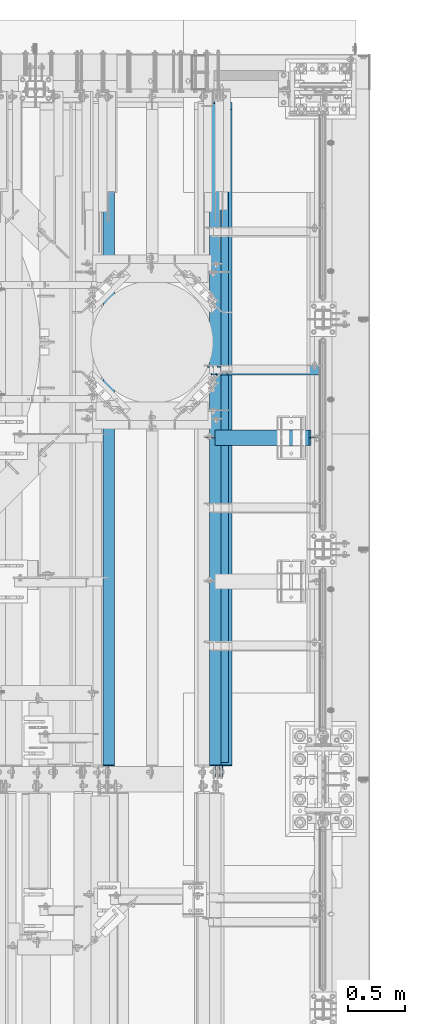
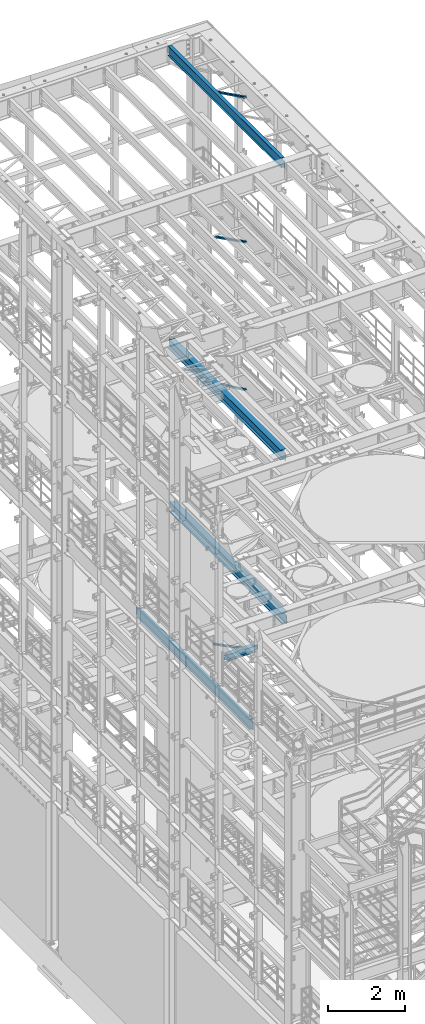
# One storey, part 1063 of 1876: 5 beams, 4 members, 9 elements without a shape of their own.
"""IFC2X3 building model written with IfcOpenShell, lengths in millimetres."""

from ifc_helpers import new_model, si_unit, frame, origin_with_axes, place, context, subcontext, project, spatial, faceted_brep, material, type_object, element, aggregate, save


model = new_model("IFC2X3")

# Units and contexts
model_context = context("Model", 3, precision=1e-05, world=origin_with_axes())
body_context = subcontext(model_context, "Body", "Model", "MODEL_VIEW")
ifc_project = project(units=[si_unit("LENGTHUNIT", "METRE", prefix="MILLI"), si_unit("AREAUNIT", "SQUARE_METRE"), si_unit("VOLUMEUNIT", "CUBIC_METRE"), si_unit("MASSUNIT", "GRAM", prefix="KILO"), si_unit("TIMEUNIT", "SECOND"), si_unit("PLANEANGLEUNIT", "RADIAN"), si_unit("SOLIDANGLEUNIT", "STERADIAN"), si_unit("THERMODYNAMICTEMPERATUREUNIT", "DEGREE_CELSIUS"), si_unit("LUMINOUSINTENSITYUNIT", "LUMEN")], contexts=[model_context])

# Site, building, storey
site_placement = place(None, origin_with_axes())
site = spatial("IfcSite", under=ifc_project, at=site_placement, CompositionType="ELEMENT")
building_placement = place(site_placement, origin_with_axes())
building = spatial("IfcBuilding", under=site, at=building_placement, Name="Undefined", CompositionType="ELEMENT")
storey_placement = place(building_placement, origin_with_axes())
storey = spatial("IfcBuildingStorey", under=building, at=storey_placement, Name="Undefined", CompositionType="ELEMENT", Elevation=0.0)

# Assembly, member
assembly_1_placement = place(storey_placement, origin_with_axes())
assembly_1 = element("IfcElementAssembly", 1, at=assembly_1_placement, inside=storey, AssemblyPlace="NOTDEFINED", PredefinedType="RIGID_FRAME")
ifc_material_1 = material(Name="STEEL/A36")
member_type = type_object("IfcMemberType", Name="L3X3X3/8", PredefinedType="NOTDEFINED")
member_1_placement = place(assembly_1_placement, frame((6546.00359127146, 11229.975, 5110.24886127725), z_axis=(0.0, -1.0, 0.0), x_axis=(0.894904191539842, 0.0, -0.446258319770535)))
member_1 = element("IfcMember", 2, at=member_1_placement, type_object=member_type, material=ifc_material_1, ObjectType="L3X3X3/8", context=body_context, shape_type="Brep", body=[
    faceted_brep([(80.1547206858395, 38.100000000054, -38.1000000000004), (80.1547206858395, 38.100000000054, 38.1000000000004), (1158.95112186373, 38.1000000006807, 38.1000000000004), (1158.95112186373, 38.1000000006807, -38.1000000000004), (80.1547206858399, 28.5750000000526, 38.1000000000004), (1158.95112186373, 28.5750000006792, 38.1000000000004), (80.1547206858399, 28.5750000000526, -28.5750000000007), (1158.95112186373, 28.5750000006792, -28.5750000000007), (80.154720685839, -38.0999999999594, -28.5750000000007), (1158.95112186373, -38.0999999993337, -28.5750000000007), (80.154720685839, -38.0999999999594, -38.1000000000004), (1158.95112186373, -38.0999999993337, -38.1000000000004)], [[[0, 1, 2, 3]], [[1, 4, 5, 2]], [[4, 6, 7, 5]], [[6, 8, 9, 7]], [[8, 10, 11, 9]], [[10, 0, 3, 11]], [[5, 7, 9, 11, 3, 2]], [[10, 8, 6, 4, 1, 0]]]),
])
aggregate(assembly_1, [member_1])

assembly_2_placement = place(storey_placement, origin_with_axes())
assembly_2 = element("IfcElementAssembly", 3, at=assembly_2_placement, inside=storey, Name="BRACE", AssemblyPlace="NOTDEFINED", PredefinedType="RIGID_FRAME")
member_2_placement = place(assembly_2_placement, frame((6673.56288393271, 11229.975, 13302.1718727092), z_axis=(0.0, -1.0, 0.0), x_axis=(0.861630637805759, 0.0, -0.507535854885584)))
member_2 = element("IfcMember", 4, at=member_2_placement, type_object=member_type, material=ifc_material_1, Name="BRACE", ObjectType="L3X3X3/8", context=body_context, shape_type="Brep", body=[
    faceted_brep([(93.8357350541173, 38.0999999999913, -38.0999999999999), (93.8357350541173, 38.0999999999913, 38.0999999999999), (1052.95263444459, 38.0999999997257, 38.0999999999999), (1052.95263444459, 38.0999999997257, -38.0999999999999), (93.8357350541228, 28.5749999999862, 38.0999999999999), (1052.95263444459, 28.5749999997206, 38.0999999999999), (93.8357350541228, 28.5749999999862, -28.5749999999998), (1052.95263444459, 28.5749999997206, -28.5749999999998), (93.8357350541537, -38.100000000044, -28.5749999999998), (1052.95263444462, -38.100000000306, -28.5749999999998), (93.8357350541537, -38.100000000044, -38.0999999999999), (1052.95263444462, -38.100000000306, -38.0999999999999)], [[[0, 1, 2, 3]], [[1, 4, 5, 2]], [[4, 6, 7, 5]], [[6, 8, 9, 7]], [[8, 10, 11, 9]], [[10, 0, 3, 11]], [[5, 7, 9, 11, 3, 2]], [[10, 8, 6, 4, 1, 0]]]),
])
aggregate(assembly_2, [member_2])

assembly_3_placement = place(storey_placement, origin_with_axes())
assembly_3 = element("IfcElementAssembly", 5, at=assembly_3_placement, inside=storey, AssemblyPlace="NOTDEFINED", PredefinedType="RIGID_FRAME")
member_3_placement = place(assembly_3_placement, frame((6649.22451200342, 11229.975, 22521.7692276093), z_axis=(0.0, -1.0, 0.0), x_axis=(0.877448093107094, 0.0, -0.479671600058544)))
member_3 = element("IfcMember", 6, at=member_3_placement, type_object=member_type, material=ifc_material_1, ObjectType="L3X3X3/8", context=body_context, shape_type="Brep", body=[
    faceted_brep([(59.7482362440578, 38.0999999998749, -38.0999999999999), (59.7482362440578, 38.0999999998749, 38.0999999999999), (1062.91900040893, 38.0999999984488, 38.0999999999999), (1062.91900040893, 38.0999999984488, -38.0999999999999), (59.7482362440696, 28.5749999998843, 38.0999999999999), (1062.91900040895, 28.5749999984582, 38.0999999999999), (59.7482362440696, 28.5749999998843, -28.5749999999998), (1062.91900040895, 28.5749999984582, -28.5749999999998), (59.7482362441442, -38.1000000000495, -28.5749999999998), (1062.91900040902, -38.1000000014719, -28.5749999999998), (59.7482362441442, -38.1000000000495, -38.0999999999999), (1062.91900040902, -38.1000000014719, -38.0999999999999)], [[[0, 1, 2, 3]], [[1, 4, 5, 2]], [[4, 6, 7, 5]], [[6, 8, 9, 7]], [[8, 10, 11, 9]], [[10, 0, 3, 11]], [[5, 7, 9, 11, 3, 2]], [[10, 8, 6, 4, 1, 0]]]),
])
aggregate(assembly_3, [member_3])

assembly_4_placement = place(storey_placement, origin_with_axes())
assembly_4 = element("IfcElementAssembly", 7, at=assembly_4_placement, inside=storey, AssemblyPlace="NOTDEFINED", PredefinedType="RIGID_FRAME")
member_4_placement = place(assembly_4_placement, frame((6548.05484608427, 11229.975, 17987.6375508032), z_axis=(0.0, -1.0, 0.0), x_axis=(0.883528850284789, 0.0, -0.46837674015096)))
member_4 = element("IfcMember", 8, at=member_4_placement, type_object=member_type, material=ifc_material_1, ObjectType="L3X3X3/8", context=body_context, shape_type="Brep", body=[
    faceted_brep([(128.795891913077, 38.1000000000095, -38.0999999999999), (128.795891913077, 38.1000000000095, 38.0999999999999), (1170.59703232476, 38.0999999999913, 38.0999999999999), (1170.59703232476, 38.0999999999913, -38.0999999999999), (128.795891913076, 28.575000000008, 38.0999999999999), (1170.59703232476, 28.5749999999898, 38.0999999999999), (128.795891913076, 28.575000000008, -28.5749999999998), (1170.59703232476, 28.5749999999898, -28.5749999999998), (128.79589191308, -38.1000000000167, -28.5749999999998), (1170.59703232476, -38.1000000000313, -28.5749999999998), (128.79589191308, -38.1000000000167, -38.0999999999999), (1170.59703232476, -38.1000000000313, -38.0999999999999)], [[[0, 1, 2, 3]], [[1, 4, 5, 2]], [[4, 6, 7, 5]], [[6, 8, 9, 7]], [[8, 10, 11, 9]], [[10, 0, 3, 11]], [[5, 7, 9, 11, 3, 2]], [[10, 8, 6, 4, 1, 0]]]),
])
aggregate(assembly_4, [member_4])

# Assembly, beam
assembly_5_placement = place(storey_placement, origin_with_axes())
assembly_5 = element("IfcElementAssembly", 9, at=assembly_5_placement, inside=storey, Name="BEAM", AssemblyPlace="NOTDEFINED", PredefinedType="RIGID_FRAME")
ifc_material_2 = material(Name="STEEL/A992")
beam_type_1 = type_object("IfcBeamType", Name="W12X16", PredefinedType="NOTDEFINED")
beam_1_placement = place(assembly_5_placement, frame((6667.5, 7620.0, 22402.8), z_axis=(0.0, 0.0, 1.0), x_axis=(0.0, 1.0, 0.0)))
beam_1 = element("IfcBeam", 10, at=beam_1_placement, type_object=beam_type_1, material=ifc_material_2, Name="BEAM", ObjectType="W12X16", context=body_context, shape_type="Brep", body=[
    faceted_brep([(19.84375, -3.17499999999995, -126.999999999996), (19.84375, 3.17499999999995, -126.999999999996), (102.393750190735, 3.17500000000018, -127.000000000001), (102.393750190735, -3.17500000000018, -127.000000000001), (107.25382970878, 3.17500000000018, -127.966729922588), (107.25382970878, -3.17500000000018, -127.966729922588), (111.374006176934, 3.17500000000018, -130.719743823067), (111.374006176934, -3.17500000000018, -130.719743823067), (114.127020077412, 3.17500000000018, -134.839920291221), (114.127020077412, -3.17500000000018, -134.839920291221), (115.09375, -3.17500000000018, -139.699999809266), (115.09375, 3.17500000000018, -139.699999809266), (115.09375, 3.17500000000018, -146.05), (115.09375, 50.8000000000002, -146.05), (115.09375, 50.8000000000002, -152.4), (115.09375, -50.8000000000002, -152.4), (115.09375, -50.8000000000002, -146.05), (115.09375, -3.17500000000018, -146.05), (127.79375, 3.17500000000018, 146.05), (127.79375, 50.8000000000002, 146.05), (5968.20625, 50.8, 146.05), (5968.20625, 3.17499999999995, 146.05), (115.093750190735, -3.17500000000018, 114.299999999999), (115.093750190735, 3.17500000000018, 114.299999999999), (19.84375, 3.17500000000018, 114.299999999999), (19.84375, -3.17500000000018, 114.299999999999), (119.95382970878, -3.17500000000018, 115.266729922587), (119.95382970878, 3.17500000000018, 115.266729922587), (124.074006176934, -3.17500000000018, 118.019743823065), (124.074006176934, 3.17500000000018, 118.019743823065), (126.827020077412, -3.17500000000018, 122.139920291219), (126.827020077412, 3.17500000000018, 122.139920291219), (127.79375, -3.17500000000018, 126.999999809264), (127.79375, 3.17500000000018, 126.999999809264), (127.79375, 50.8000000000002, 152.4), (127.79375, -50.8000000000002, 152.4), (5968.20625, -50.8, 152.4), (5968.20625, 50.8, 152.4), (127.79375, -50.8000000000002, 146.05), (5968.20625, -50.8, 146.05), (127.79375, -3.17500000000018, 146.05), (5968.20625, -3.17499999999995, 146.05), (5968.20625, -3.17499999999995, 126.999999809264), (5968.20625, 3.17499999999995, 126.999999809264), (5969.17297992259, -3.17499999999995, 122.139920291219), (5969.17297992259, 3.17499999999995, 122.139920291219), (5971.92599382307, -3.17499999999995, 118.019743823065), (5971.92599382307, 3.17499999999995, 118.019743823065), (5976.04617029122, -3.17499999999995, 115.266729922587), (5976.04617029122, 3.17499999999995, 115.266729922587), (5980.90624980927, -3.17499999999995, 114.299999999999), (5980.90624980927, 3.17499999999995, 114.299999999999), (6076.15625, -3.17499999999995, 114.299999999999), (6076.15625, 3.17499999999995, 114.299999999999), (6076.15625, -3.17499999999995, -126.999999999996), (6076.15625, 3.17499999999995, -126.999999999996), (5993.60624980927, -3.17499999999995, -127.000000000001), (5993.60624980927, 3.17499999999995, -127.000000000001), (5988.74617029122, -3.17499999999995, -127.966729922588), (5988.74617029122, 3.17499999999995, -127.966729922588), (5984.62599382307, -3.17499999999995, -130.719743823067), (5984.62599382307, 3.17499999999995, -130.719743823067), (5981.87297992259, -3.17499999999995, -134.839920291221), (5981.87297992259, 3.17499999999995, -134.839920291221), (5980.90625, -3.17499999999995, -139.699999809266), (5980.90625, 3.17499999999995, -139.699999809266), (5980.90625, -3.17499999999995, -146.05), (5980.90625, -50.8, -146.05), (5980.90625, -50.8, -152.4), (5980.90625, 50.8, -152.4), (5980.90625, 50.8, -146.05), (5980.90625, 3.17499999999995, -146.05)], [[[0, 1, 2, 3]], [[3, 2, 4, 5]], [[5, 4, 6, 7]], [[7, 6, 8, 9]], [[10, 11, 12, 13, 14, 15, 16, 17]], [[9, 8, 11, 10]], [[18, 19, 20, 21]], [[22, 23, 24, 25]], [[26, 27, 23, 22]], [[28, 29, 27, 26]], [[30, 31, 29, 28]], [[32, 33, 31, 30]], [[34, 35, 36, 37]], [[35, 38, 39, 36]], [[38, 40, 41, 39]], [[35, 34, 19, 18, 33, 32, 40, 38]], [[19, 34, 37, 20]], [[36, 39, 41, 42, 43, 21, 20, 37]], [[44, 45, 43, 42]], [[46, 47, 45, 44]], [[48, 49, 47, 46]], [[50, 51, 49, 48]], [[52, 53, 51, 50]], [[53, 52, 54, 55]], [[54, 56, 57, 55]], [[58, 59, 57, 56]], [[60, 61, 59, 58]], [[62, 63, 61, 60]], [[64, 65, 63, 62]], [[66, 67, 68, 69, 70, 71, 65, 64]], [[17, 16, 67, 66]], [[16, 15, 68, 67]], [[15, 14, 69, 68]], [[14, 13, 70, 69]], [[13, 12, 71, 70]], [[59, 61, 63, 65, 71, 12, 11, 8, 6, 4, 2, 1, 24, 23, 27, 29, 31, 33, 18, 21, 43, 45, 47, 49, 51, 53, 55, 57]], [[25, 24, 1, 0]], [[52, 50, 48, 46, 44, 42, 41, 40, 32, 30, 28, 26, 22, 25, 0, 3, 5, 7, 9, 10, 17, 66, 64, 62, 60, 58, 56, 54]]]),
])
aggregate(assembly_5, [beam_1])

assembly_6_placement = place(storey_placement, origin_with_axes())
assembly_6 = element("IfcElementAssembly", 11, at=assembly_6_placement, inside=storey, Name="BEAM", AssemblyPlace="NOTDEFINED", PredefinedType="RIGID_FRAME")
beam_2_placement = place(assembly_6_placement, frame((5727.7, 7620.0, 4978.4), z_axis=(0.0, 0.0, 1.0), x_axis=(0.0, 1.0, 0.0)))
beam_2 = element("IfcBeam", 12, at=beam_2_placement, type_object=beam_type_1, material=ifc_material_2, Name="BEAM", ObjectType="W12X16", context=body_context, shape_type="Brep", body=[
    faceted_brep([(19.84375, -3.17499999999995, -126.999999999996), (19.84375, 3.17499999999995, -126.999999999996), (102.393750190735, 3.17500000000018, -127.000000000001), (102.393750190735, -3.17500000000018, -127.000000000001), (107.25382970878, 3.17500000000018, -127.966729922588), (107.25382970878, -3.17500000000018, -127.966729922588), (111.374006176934, 3.17500000000018, -130.719743823067), (111.374006176934, -3.17500000000018, -130.719743823067), (114.127020077412, 3.17500000000018, -134.839920291221), (114.127020077412, -3.17500000000018, -134.839920291221), (115.09375, -3.17500000000018, -139.699999809266), (115.09375, 3.17500000000018, -139.699999809266), (115.09375, 3.17500000000018, -146.05), (115.09375, 50.8000000000002, -146.05), (115.09375, 50.8000000000002, -152.4), (115.09375, -50.8000000000002, -152.4), (115.09375, -50.8000000000002, -146.05), (115.09375, -3.17500000000018, -146.05), (5914.23125, 50.8, 146.05), (5914.23125, 3.17500000000018, 146.05), (127.79375, 3.17500000000018, 146.05), (127.79375, 50.8000000000002, 146.05), (115.093750190735, -3.17500000000018, 114.299999999999), (115.093750190735, 3.17500000000018, 114.299999999999), (19.84375, 3.17500000000018, 114.299999999999), (19.84375, -3.17500000000018, 114.299999999999), (119.95382970878, -3.17500000000018, 115.266729922587), (119.95382970878, 3.17500000000018, 115.266729922587), (124.074006176934, -3.17500000000018, 118.019743823065), (124.074006176934, 3.17500000000018, 118.019743823065), (126.827020077412, -3.17500000000018, 122.139920291219), (126.827020077412, 3.17500000000018, 122.139920291219), (127.79375, -3.17500000000018, 126.999999809264), (127.79375, 3.17500000000018, 126.999999809264), (5914.23125, -50.8, 152.4), (5914.23125, 50.8, 152.4), (127.79375, 50.8000000000002, 152.4), (127.79375, -50.8000000000002, 152.4), (5914.23125, -50.8, 146.05), (127.79375, -50.8000000000002, 146.05), (5914.23125, -3.17500000000018, 146.05), (127.79375, -3.17500000000018, 146.05), (5914.23125, -3.17499999999995, 114.299999809266), (5914.23125, 3.17499999999995, 114.299999809266), (5915.19797992259, -3.17499999999995, 109.43992029122), (5915.19797992259, 3.17499999999995, 109.43992029122), (5917.95099382307, -3.17499999999995, 105.319743823066), (5917.95099382307, 3.17499999999995, 105.319743823066), (5922.07117029122, -3.17499999999995, 102.566729922588), (5922.07117029122, 3.17499999999995, 102.566729922588), (5926.93124980926, -3.17499999999995, 101.6), (5926.93124980926, 3.17499999999995, 101.6), (6072.98125, -3.17499999999995, 101.6), (6072.98125, 3.17499999999995, 101.6), (6072.98125, -3.17499999999995, -127.0), (6072.98125, 3.17499999999995, -127.0), (5990.43124980926, -3.17499999999995, -127.0), (5990.43124980926, 3.17499999999995, -127.0), (5985.57117029122, -3.17499999999995, -127.966729922588), (5985.57117029122, 3.17499999999995, -127.966729922588), (5981.45099382307, -3.17499999999995, -130.719743823066), (5981.45099382307, 3.17499999999995, -130.719743823066), (5978.69797992259, -3.17499999999995, -134.83992029122), (5978.69797992259, 3.17499999999995, -134.83992029122), (5977.73125, -3.17499999999995, -139.699999809265), (5977.73125, 3.17499999999995, -139.699999809265), (5977.73125, -3.17500000000018, -146.05), (5977.73125, -50.8, -146.05), (5977.73125, -50.8, -152.4), (5977.73125, 50.8, -152.4), (5977.73125, 50.8, -146.05), (5977.73125, 3.17500000000018, -146.05)], [[[0, 1, 2, 3]], [[3, 2, 4, 5]], [[5, 4, 6, 7]], [[7, 6, 8, 9]], [[10, 11, 12, 13, 14, 15, 16, 17]], [[9, 8, 11, 10]], [[18, 19, 20, 21]], [[22, 23, 24, 25]], [[26, 27, 23, 22]], [[28, 29, 27, 26]], [[30, 31, 29, 28]], [[32, 33, 31, 30]], [[34, 35, 36, 37]], [[38, 34, 37, 39]], [[40, 38, 39, 41]], [[37, 36, 21, 20, 33, 32, 41, 39]], [[35, 18, 21, 36]], [[34, 38, 40, 42, 43, 19, 18, 35]], [[44, 45, 43, 42]], [[46, 47, 45, 44]], [[48, 49, 47, 46]], [[50, 51, 49, 48]], [[52, 53, 51, 50]], [[53, 52, 54, 55]], [[54, 56, 57, 55]], [[58, 59, 57, 56]], [[60, 61, 59, 58]], [[62, 63, 61, 60]], [[64, 65, 63, 62]], [[66, 67, 68, 69, 70, 71, 65, 64]], [[67, 66, 17, 16]], [[68, 67, 16, 15]], [[69, 68, 15, 14]], [[70, 69, 14, 13]], [[71, 70, 13, 12]], [[6, 4, 2, 1, 24, 23, 27, 29, 31, 33, 20, 19, 43, 45, 47, 49, 51, 53, 55, 57, 59, 61, 63, 65, 71, 12, 11, 8]], [[25, 24, 1, 0]], [[66, 64, 62, 60, 58, 56, 54, 52, 50, 48, 46, 44, 42, 40, 41, 32, 30, 28, 26, 22, 25, 0, 3, 5, 7, 9, 10, 17]]]),
])
aggregate(assembly_6, [beam_2])

assembly_7_placement = place(storey_placement, origin_with_axes())
assembly_7 = element("IfcElementAssembly", 13, at=assembly_7_placement, inside=storey, Name="BEAM", AssemblyPlace="NOTDEFINED", PredefinedType="RIGID_FRAME")
beam_type_2 = type_object("IfcBeamType", Name="W8X18", PredefinedType="NOTDEFINED")
beam_3_placement = place(assembly_7_placement, frame((6553.2, 10636.25, 5027.6125), z_axis=(0.0, 0.0, 1.0), x_axis=(1.0, 0.0, 0.0)))
beam_3 = element("IfcBeam", 14, at=beam_3_placement, type_object=beam_type_2, material=ifc_material_2, Name="BEAM", ObjectType="W8X18", context=body_context, shape_type="Brep", body=[
    faceted_brep([(958.056250000001, -3.17499999999927, -95.25), (958.056250000001, -66.6749999999993, -95.25), (958.056250000002, -66.6749999999993, -103.1875), (958.056250000002, 66.6749999999993, -103.1875), (958.056250000001, 66.6749999999993, -95.25), (958.056250000001, 3.17499999999927, -95.25), (958.056250000001, 3.17499999999927, -90.4874998092664), (958.056250000001, -3.17499999999927, -90.4874998092664), (959.022979922589, 3.17499999999927, -85.6274202912209), (959.022979922589, -3.17499999999927, -85.6274202912209), (961.775993823067, 3.17499999999927, -81.5072438230673), (961.775993823067, -3.17499999999927, -81.5072438230673), (965.896170291221, 3.17499999999927, -78.7542299225888), (965.896170291221, -3.17499999999927, -78.7542299225888), (970.756249809267, 3.17499999999927, -77.7875000000013), (970.756249809267, -3.17499999999927, -77.7875000000013), (1046.95625, -3.17499999999927, -77.7875000000013), (1046.95625, 3.17499999999927, -77.7875000000013), (111.125000000002, 3.17499999999927, 95.25), (111.125000000002, 66.6749999999993, 95.25), (940.593750000002, 66.6749999999993, 95.25), (940.593750000002, 3.17499999999927, 95.25), (117.475000000001, -3.17499999999927, -90.4874998092664), (117.475000000001, 3.17499999999927, -90.4874998092664), (117.475000000001, 3.17499999999927, -95.25), (117.475000000001, 66.6749999999993, -95.25), (117.475000000001, 66.6749999999993, -103.1875), (117.475000000001, -66.6749999999993, -103.1875), (117.475000000001, -66.6749999999993, -95.25), (117.475000000001, -3.17499999999927, -95.25), (116.508270077414, -3.17499999999927, -85.6274202912209), (116.508270077414, 3.17499999999927, -85.6274202912209), (113.755256176935, -3.17499999999927, -81.5072438230673), (113.755256176935, 3.17499999999927, -81.5072438230673), (109.635079708782, -3.17499999999927, -78.7542299225888), (109.635079708782, 3.17499999999927, -78.7542299225888), (104.775000190736, -3.17499999999927, -77.7875000000013), (104.775000190736, 3.17499999999927, -77.7875000000013), (28.5750000000016, -3.17499999999927, -77.7875000000013), (28.5750000000016, 3.17499999999927, -77.7875000000013), (28.5750000000016, -3.17499999999927, 77.7875000000013), (28.5750000000016, 3.17499999999927, 77.7875000000013), (98.4250001907367, -3.17499999999927, 77.7875000000013), (98.4250001907367, 3.17499999999927, 77.7875000000013), (103.285079708782, -3.17499999999927, 78.7542299225888), (103.285079708782, 3.17499999999927, 78.7542299225888), (107.405256176936, -3.17499999999927, 81.5072438230673), (107.405256176936, 3.17499999999927, 81.5072438230673), (110.158270077414, -3.17499999999927, 85.6274202912209), (110.158270077414, 3.17499999999927, 85.6274202912209), (111.125000000002, -3.17499999999927, 90.4874998092664), (111.125000000002, 3.17499999999927, 90.4874998092664), (111.125000000002, -66.6749999999993, 103.1875), (111.125000000002, 66.6749999999993, 103.1875), (111.125000000002, -3.17499999999927, 95.25), (111.125000000002, -66.6749999999993, 95.25), (940.593750000002, -3.17499999999927, 95.25), (940.593750000002, -66.6749999999993, 95.25), (940.593750000002, -66.6749999999993, 103.1875), (940.593750000002, 66.6749999999993, 103.1875), (940.593750000002, -3.17499999999927, 77.7874998092639), (940.593750000002, 3.17499999999927, 77.7874998092639), (941.560479922589, -3.17499999999927, 72.9274202912184), (941.560479922589, 3.17499999999927, 72.9274202912184), (944.313493823068, -3.17499999999927, 68.8072438230647), (944.313493823068, 3.17499999999927, 68.8072438230647), (948.433670291221, -3.17499999999927, 66.0542299225863), (948.433670291221, 3.17499999999927, 66.0542299225863), (953.293749809267, -3.17499999999927, 65.0874999999987), (953.293749809267, 3.17499999999927, 65.0874999999987), (1046.95625, -3.17499999999927, 65.0874999999987), (1046.95625, 3.17499999999927, 65.0874999999987)], [[[0, 1, 2, 3, 4, 5, 6, 7]], [[7, 6, 8, 9]], [[9, 8, 10, 11]], [[11, 10, 12, 13]], [[13, 12, 14, 15]], [[16, 15, 14, 17]], [[18, 19, 20, 21]], [[22, 23, 24, 25, 26, 27, 28, 29]], [[30, 31, 23, 22]], [[32, 33, 31, 30]], [[34, 35, 33, 32]], [[36, 37, 35, 34]], [[38, 39, 37, 36]], [[40, 41, 39, 38]], [[42, 43, 41, 40]], [[44, 45, 43, 42]], [[46, 47, 45, 44]], [[48, 49, 47, 46]], [[50, 51, 49, 48]], [[52, 53, 19, 18, 51, 50, 54, 55]], [[55, 54, 56, 57]], [[52, 55, 57, 58]], [[53, 52, 58, 59]], [[19, 53, 59, 20]], [[58, 57, 56, 60, 61, 21, 20, 59]], [[62, 63, 61, 60]], [[64, 65, 63, 62]], [[66, 67, 65, 64]], [[68, 69, 67, 66]], [[70, 71, 69, 68]], [[71, 70, 16, 17]], [[12, 10, 8, 6, 5, 24, 23, 31, 33, 35, 37, 39, 41, 43, 45, 47, 49, 51, 18, 21, 61, 63, 65, 67, 69, 71, 17, 14]], [[25, 24, 5, 4]], [[26, 25, 4, 3]], [[27, 26, 3, 2]], [[28, 27, 2, 1]], [[29, 28, 1, 0]], [[70, 68, 66, 64, 62, 60, 56, 54, 50, 48, 46, 44, 42, 40, 38, 36, 34, 32, 30, 22, 29, 0, 7, 9, 11, 13, 15, 16]]]),
])
aggregate(assembly_7, [beam_3])

assembly_8_placement = place(storey_placement, origin_with_axes())
assembly_8 = element("IfcElementAssembly", 15, at=assembly_8_placement, inside=storey, Name="BEAM", AssemblyPlace="NOTDEFINED", PredefinedType="RIGID_FRAME")
beam_type_3 = type_object("IfcBeamType", Name="W12X30", PredefinedType="NOTDEFINED")
beam_4_placement = place(assembly_8_placement, frame((6702.425, 7620.0, 13152.4375), z_axis=(0.0, 0.0, 1.0), x_axis=(0.0, 1.0, 0.0)))
beam_4 = element("IfcBeam", 16, at=beam_4_placement, type_object=beam_type_3, material=ifc_material_2, Name="BEAM", ObjectType="W12X30", context=body_context, shape_type="Brep", body=[
    faceted_brep([(5973.7625, -3.17500000000018, -146.049999999999), (5973.7625, -82.5500000000002, -146.049999999999), (5973.7625, -82.5500000000002, -157.1625), (5973.7625, 82.5500000000002, -157.1625), (5973.7625, 82.5500000000002, -146.049999999999), (5973.7625, 3.17500000000018, -146.049999999999), (5973.7625, 3.17500000000018, -144.462499809264), (5973.7625, -3.17500000000018, -144.462499809264), (5974.72922992259, 3.17500000000018, -139.602420291218), (5974.72922992259, -3.17500000000018, -139.602420291218), (5977.48224382307, 3.17500000000018, -135.482243823064), (5977.48224382307, -3.17500000000018, -135.482243823064), (5981.60242029122, 3.17500000000018, -132.729229922586), (5981.60242029122, -3.17500000000018, -132.729229922586), (5986.46249980926, 3.17500000000018, -131.762499999999), (5986.46249980926, -3.17500000000018, -131.762499999999), (6075.3625, -3.17500000000018, -131.762499999999), (6075.3625, 3.17500000000018, -131.762499999999), (146.84375, 3.17500000000018, 146.049999999999), (146.84375, 82.5500000000002, 146.049999999999), (5910.2625, 82.5500000000002, 146.049999999999), (5910.2625, 3.17500000000018, 146.049999999999), (146.84375, -3.17500000000018, -144.462499809266), (146.84375, 3.17500000000018, -144.462499809266), (146.84375, 3.17500000000018, -146.049999999999), (146.84375, 82.5500000000002, -146.049999999999), (146.84375, 82.5500000000002, -157.1625), (146.84375, -82.5500000000002, -157.1625), (146.84375, -82.5500000000002, -146.049999999999), (146.84375, -3.17500000000018, -146.049999999999), (145.877020077412, -3.17500000000018, -139.602420291219), (145.877020077412, 3.17500000000018, -139.602420291219), (143.124006176934, -3.17500000000018, -135.482243823066), (143.124006176934, 3.17500000000018, -135.482243823066), (139.00382970878, -3.17500000000018, -132.729229922588), (139.00382970878, 3.17500000000018, -132.729229922588), (134.143750190735, -3.17500000000018, -131.762500000001), (134.143750190735, 3.17500000000018, -131.762500000001), (19.8437500000002, -3.17500000000018, -131.762499999993), (19.8437500000002, 3.17500000000018, -131.762499999993), (19.8437491105051, -3.17499999999995, 119.062500000004), (19.8437491105051, 3.17499999999995, 119.062500000004), (134.143750190735, -3.17500000000018, 119.0625), (134.143750190735, 3.17500000000018, 119.0625), (139.00382970878, -3.17500000000018, 120.029229922588), (139.00382970878, 3.17500000000018, 120.029229922588), (143.124006176934, -3.17500000000018, 122.782243823065), (143.124006176934, 3.17500000000018, 122.782243823065), (145.877020077412, -3.17500000000018, 126.902420291219), (145.877020077412, 3.17500000000018, 126.902420291219), (146.84375, -3.17500000000018, 131.762499809265), (146.84375, 3.17500000000018, 131.762499809265), (146.84375, -82.5500000000002, 157.1625), (146.84375, 82.5500000000002, 157.1625), (146.84375, -3.17500000000018, 146.049999999999), (146.84375, -82.5500000000002, 146.049999999999), (5910.2625, -3.17500000000018, 146.049999999999), (5910.2625, -82.5500000000002, 146.049999999999), (5910.2625, -82.5500000000002, 157.1625), (5910.2625, 82.5500000000002, 157.1625), (5910.2625, -3.17500000000018, 125.412499809268), (5910.2625, 3.17500000000018, 125.412499809268), (5911.22922992259, -3.17500000000018, 120.552420291222), (5911.22922992259, 3.17500000000018, 120.552420291222), (5913.98224382307, -3.17500000000018, 116.432243823068), (5913.98224382307, 3.17500000000018, 116.432243823068), (5918.10242029122, -3.17500000000018, 113.679229922591), (5918.10242029122, 3.17500000000018, 113.679229922591), (5922.96249980926, -3.17500000000018, 112.712500000003), (5922.96249980926, 3.17500000000018, 112.712500000003), (6075.3625, -3.17500000000018, 112.712500000003), (6075.3625, 3.17500000000018, 112.712500000003)], [[[0, 1, 2, 3, 4, 5, 6, 7]], [[7, 6, 8, 9]], [[9, 8, 10, 11]], [[11, 10, 12, 13]], [[13, 12, 14, 15]], [[16, 15, 14, 17]], [[18, 19, 20, 21]], [[22, 23, 24, 25, 26, 27, 28, 29]], [[30, 31, 23, 22]], [[32, 33, 31, 30]], [[34, 35, 33, 32]], [[36, 37, 35, 34]], [[38, 39, 37, 36]], [[40, 41, 39, 38]], [[42, 43, 41, 40]], [[44, 45, 43, 42]], [[46, 47, 45, 44]], [[48, 49, 47, 46]], [[50, 51, 49, 48]], [[52, 53, 19, 18, 51, 50, 54, 55]], [[55, 54, 56, 57]], [[52, 55, 57, 58]], [[53, 52, 58, 59]], [[19, 53, 59, 20]], [[58, 57, 56, 60, 61, 21, 20, 59]], [[62, 63, 61, 60]], [[64, 65, 63, 62]], [[66, 67, 65, 64]], [[68, 69, 67, 66]], [[70, 71, 69, 68]], [[71, 70, 16, 17]], [[12, 10, 8, 6, 5, 24, 23, 31, 33, 35, 37, 39, 41, 43, 45, 47, 49, 51, 18, 21, 61, 63, 65, 67, 69, 71, 17, 14]], [[25, 24, 5, 4]], [[26, 25, 4, 3]], [[27, 26, 3, 2]], [[28, 27, 2, 1]], [[29, 28, 1, 0]], [[70, 68, 66, 64, 62, 60, 56, 54, 50, 48, 46, 44, 42, 40, 38, 36, 34, 32, 30, 22, 29, 0, 7, 9, 11, 13, 15, 16]]]),
])
aggregate(assembly_8, [beam_4])

assembly_9_placement = place(storey_placement, origin_with_axes())
assembly_9 = element("IfcElementAssembly", 17, at=assembly_9_placement, inside=storey, Name="BEAM", AssemblyPlace="NOTDEFINED", PredefinedType="RIGID_FRAME")
beam_5_placement = place(assembly_9_placement, frame((6731.0, 7620.0, 7996.2375), z_axis=(0.0, 0.0, 1.0), x_axis=(0.0, 1.0, 0.0)))
beam_5 = element("IfcBeam", 18, at=beam_5_placement, type_object=beam_type_3, material=ifc_material_2, Name="BEAM", ObjectType="W12X30", context=body_context, shape_type="Brep", body=[
    faceted_brep([(19.8437500000002, -3.17500000000018, -131.762499999993), (19.8437500000002, 3.17500000000018, -131.762499999993), (102.393750190735, 3.17500000000018, -131.762500000001), (102.393750190735, -3.17500000000018, -131.762500000001), (107.25382970878, 3.17500000000018, -132.729229922588), (107.25382970878, -3.17500000000018, -132.729229922588), (111.374006176934, 3.17500000000018, -135.482243823067), (111.374006176934, -3.17500000000018, -135.482243823067), (114.127020077412, 3.17500000000018, -139.60242029122), (114.127020077412, -3.17500000000018, -139.60242029122), (115.09375, -3.17500000000018, -144.462499809266), (115.09375, 3.17500000000018, -144.462499809266), (115.09375, 3.17500000000018, -146.05), (115.09375, 82.5500000000002, -146.05), (115.09375, 82.5500000000002, -157.1625), (115.09375, -82.5500000000002, -157.1625), (115.09375, -82.5500000000002, -146.05), (115.09375, -3.17500000000018, -146.05), (5914.23125, 82.5500000000002, 146.05), (5914.23125, 3.17500000000018, 146.05), (127.79375, 3.17500000000018, 146.05), (127.793782276814, 82.5500000000102, 146.05), (115.09374930124, -3.17499999999995, 119.062500000004), (115.09374930124, 3.17499999999995, 119.062500000004), (19.8437491105051, 3.17499999999995, 119.062500000004), (19.8437491105051, -3.17499999999995, 119.062500000004), (119.953828819285, -3.17499999999995, 120.029229922591), (119.953828819285, 3.17499999999995, 120.029229922591), (124.074005287439, -3.17499999999995, 122.782243823069), (124.074005287439, 3.17499999999995, 122.782243823069), (126.827019187917, -3.17499999999995, 126.902420291222), (126.827019187917, 3.17499999999995, 126.902420291222), (127.793749110505, -3.17499999999995, 131.762499809269), (127.793749110505, 3.17499999999995, 131.762499809269), (5914.23125, -82.5500000000002, 157.1625), (5914.23125, 82.5500000000002, 157.1625), (127.793749110505, 82.55, 157.162499999999), (127.793749110505, -82.55, 157.162499999999), (5914.23125, -82.5500000000002, 146.05), (127.793782276821, -82.5500000000029, 146.05), (5914.23125, -3.17500000000018, 146.05), (127.79375, -3.17500000000018, 146.05), (5914.23125, -3.17500000000018, 119.062499809265), (5914.23125, 3.17500000000018, 119.062499809265), (5915.19797992259, -3.17500000000018, 114.20242029122), (5915.19797992259, 3.17500000000018, 114.20242029122), (5917.95099382307, -3.17500000000018, 110.082243823066), (5917.95099382307, 3.17500000000018, 110.082243823066), (5922.07117029122, -3.17500000000018, 107.329229922588), (5922.07117029122, 3.17500000000018, 107.329229922588), (5926.93124980926, -3.17500000000018, 106.3625), (5926.93124980926, 3.17500000000018, 106.3625), (6072.98125, -3.17500000000018, 106.3625), (6072.98125, 3.17500000000018, 106.3625), (6072.98125, -3.17500000000018, -131.7625), (6072.98125, 3.17500000000018, -131.7625), (5990.43124980926, -3.17500000000018, -131.7625), (5990.43124980926, 3.17500000000018, -131.7625), (5985.57117029122, -3.17500000000018, -132.729229922587), (5985.57117029122, 3.17500000000018, -132.729229922587), (5981.45099382307, -3.17500000000018, -135.482243823066), (5981.45099382307, 3.17500000000018, -135.482243823066), (5978.69797992259, -3.17500000000018, -139.602420291219), (5978.69797992259, 3.17500000000018, -139.602420291219), (5977.73125, -3.17500000000018, -144.462499809265), (5977.73125, 3.17500000000018, -144.462499809265), (5977.73125, -3.17500000000018, -146.05), (5977.73125, -82.5500000000002, -146.05), (5977.73125, -82.5500000000002, -157.1625), (5977.73125, 82.5500000000002, -157.1625), (5977.73125, 82.5500000000002, -146.05), (5977.73125, 3.17500000000018, -146.05)], [[[0, 1, 2, 3]], [[3, 2, 4, 5]], [[5, 4, 6, 7]], [[7, 6, 8, 9]], [[10, 11, 12, 13, 14, 15, 16, 17]], [[9, 8, 11, 10]], [[18, 19, 20, 21]], [[22, 23, 24, 25]], [[26, 27, 23, 22]], [[28, 29, 27, 26]], [[30, 31, 29, 28]], [[32, 33, 31, 30]], [[34, 35, 36, 37]], [[38, 34, 37, 39]], [[40, 38, 39, 41]], [[37, 36, 21, 20, 33, 32, 41, 39]], [[35, 18, 21, 36]], [[34, 38, 40, 42, 43, 19, 18, 35]], [[44, 45, 43, 42]], [[46, 47, 45, 44]], [[48, 49, 47, 46]], [[50, 51, 49, 48]], [[52, 53, 51, 50]], [[53, 52, 54, 55]], [[54, 56, 57, 55]], [[58, 59, 57, 56]], [[60, 61, 59, 58]], [[62, 63, 61, 60]], [[64, 65, 63, 62]], [[66, 67, 68, 69, 70, 71, 65, 64]], [[67, 66, 17, 16]], [[68, 67, 16, 15]], [[69, 68, 15, 14]], [[70, 69, 14, 13]], [[71, 70, 13, 12]], [[6, 4, 2, 1, 24, 23, 27, 29, 31, 33, 20, 19, 43, 45, 47, 49, 51, 53, 55, 57, 59, 61, 63, 65, 71, 12, 11, 8]], [[25, 24, 1, 0]], [[66, 64, 62, 60, 58, 56, 54, 52, 50, 48, 46, 44, 42, 40, 41, 32, 30, 28, 26, 22, 25, 0, 3, 5, 7, 9, 10, 17]]]),
])
aggregate(assembly_9, [beam_5])

save(model, "model.ifc")
